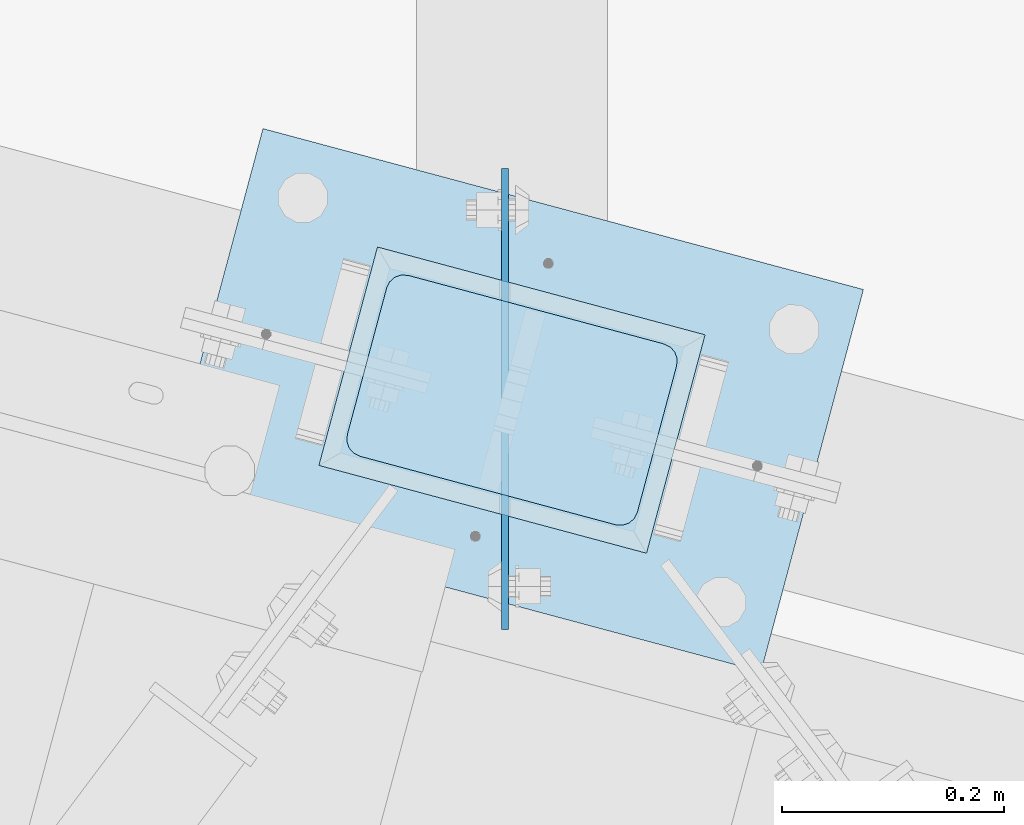
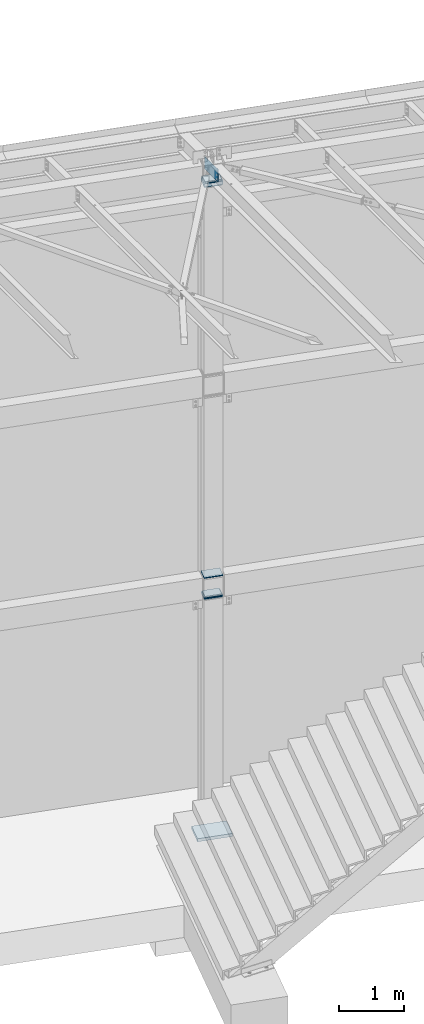
# One storey, part 1690 of 1763: 9 plates, 1 element without a shape of its own.
"""IFC2X3 building model written with IfcOpenShell, lengths in millimetres."""

from ifc_helpers import new_model, si_unit, frame, origin_with_axes, place, context, subcontext, project, spatial, faceted_brep, material, type_object, element, aggregate, save


model = new_model("IFC2X3")

# Units and contexts
model_context = context("Model", 3, precision=1e-05, world=origin_with_axes())
body_context = subcontext(model_context, "Body", "Model", "MODEL_VIEW")
ifc_project = project(units=[si_unit("LENGTHUNIT", "METRE", prefix="MILLI"), si_unit("AREAUNIT", "SQUARE_METRE"), si_unit("VOLUMEUNIT", "CUBIC_METRE"), si_unit("MASSUNIT", "GRAM", prefix="KILO"), si_unit("TIMEUNIT", "SECOND"), si_unit("PLANEANGLEUNIT", "RADIAN"), si_unit("SOLIDANGLEUNIT", "STERADIAN"), si_unit("THERMODYNAMICTEMPERATUREUNIT", "DEGREE_CELSIUS"), si_unit("LUMINOUSINTENSITYUNIT", "LUMEN")], contexts=[model_context])

# Site, building, storey
site_placement = place(None, origin_with_axes())
site = spatial("IfcSite", under=ifc_project, at=site_placement, CompositionType="ELEMENT")
building_placement = place(site_placement, origin_with_axes())
building = spatial("IfcBuilding", under=site, at=building_placement, Name="Undefined", CompositionType="ELEMENT")
storey_placement = place(building_placement, origin_with_axes())
storey = spatial("IfcBuildingStorey", under=building, at=storey_placement, Name="Undefined", CompositionType="ELEMENT", Elevation=0.0)

# Assembly, plates
assembly_placement = place(storey_placement, origin_with_axes())
assembly = element("IfcElementAssembly", 1, at=assembly_placement, inside=storey, Name="COLUMN", AssemblyPlace="NOTDEFINED", PredefinedType="RIGID_FRAME")
ifc_material_1 = material(Name="STEEL/A36")
plate_type_1 = type_object("IfcPlateType", PredefinedType="NOTDEFINED")
plate_1_placement = place(assembly_placement, frame((-31217.8672022489, 64503.1592394431, 4295.775), z_axis=(0.965913267114843, -0.258865912030785, 0.0), x_axis=(-0.258865912030778, -0.965913267114844, 3.00823476209188e-08)))
plate_1 = element("IfcPlate", 2, at=plate_1_placement, type_object=plate_type_1, material=ifc_material_1, Name="PLATE", context=body_context, shape_type="Brep", body=[
    faceted_brep([(-2.18278728425503e-11, -12.7000000000007, 15.875), (-1.67347025126219e-10, -12.7000000000007, 253.999999999985), (-1.67347025126219e-10, 12.7000000000007, 253.999999999985), (-2.18278728425503e-11, 12.7000000000007, 15.875), (1.20841242121242, -12.7000000000007, 260.075099488779), (1.20841242121242, 12.7000000000007, 260.075099488779), (4.649679848495, -12.7000000000007, 265.225320151323), (4.649679848495, 12.7000000000007, 265.225320151323), (9.79990051103232, -12.7000000000007, 268.666587578606), (9.79990051103232, 12.7000000000007, 268.666587578606), (15.8749999998181, -12.7000000000007, 269.874999999993), (15.8749999998181, 12.7000000000007, 269.874999999993), (152.400009155084, -12.7000000000007, 269.875000000073), (152.400009155084, 12.7000000000007, 269.875000000073), (158.475108643877, -12.7000000000007, 268.6665875787), (158.475108643877, 12.7000000000007, 268.6665875787), (163.625329306422, -12.7000000000007, 265.225320151425), (163.625329306422, 12.7000000000007, 265.225320151425), (167.066596733705, -12.7000000000007, 260.07509948888), (167.066596733705, 12.7000000000007, 260.07509948888), (168.275009155092, -12.7000000000007, 254.000000000087), (168.275009155092, 12.7000000000007, 254.000000000087), (168.275009155237, -12.7000000000007, 15.8750000001019), (168.275009155237, 12.7000000000007, 15.8750000001019), (167.066596733865, -12.7000000000007, 9.79990051130881), (167.066596733865, 12.7000000000007, 9.79990051130881), (163.625329306582, -12.7000000000007, 4.64967984876421), (163.625329306582, 12.7000000000007, 4.64967984876421), (158.475108644045, -12.7000000000007, 1.20841242148163), (158.475108644045, 12.7000000000007, 1.20841242148163), (152.400000000001, -12.6999998092651, 0.0), (152.400000000001, 12.6999998092651, 0.0), (15.8749999999854, -12.7000000000007, 0.0), (15.8749999999854, 12.7000000000007, 0.0), (9.79990051119239, -12.7000000000007, 1.20841242137976), (9.79990051119239, 12.7000000000007, 1.20841242137976), (4.64967984864779, -12.7000000000007, 4.64967984866234), (4.64967984864779, 12.7000000000007, 4.64967984866234), (1.20841242136521, -12.7000000000007, 9.79990051119967), (1.20841242136521, 12.7000000000007, 9.79990051119967)], [[[0, 1, 2, 3]], [[1, 4, 5, 2]], [[4, 6, 7, 5]], [[6, 8, 9, 7]], [[8, 10, 11, 9]], [[10, 12, 13, 11]], [[12, 14, 15, 13]], [[14, 16, 17, 15]], [[16, 18, 19, 17]], [[18, 20, 21, 19]], [[20, 22, 23, 21]], [[22, 24, 25, 23]], [[24, 26, 27, 25]], [[26, 28, 29, 27]], [[28, 30, 31, 29]], [[30, 32, 33, 31]], [[32, 34, 35, 33]], [[34, 36, 37, 35]], [[36, 38, 39, 37]], [[38, 0, 3, 39]], [[5, 7, 9, 11, 13, 15, 17, 19, 21, 23, 25, 27, 29, 31, 33, 35, 37, 39, 3, 2]], [[38, 36, 34, 32, 30, 28, 26, 24, 22, 20, 18, 16, 14, 12, 10, 8, 6, 4, 1, 0]]]),
])
plate_2_placement = place(assembly_placement, frame((-31217.8672022863, 64503.1592394531, 4254.5), z_axis=(0.965913267114843, -0.258865912030785, 0.0), x_axis=(-0.258865912030778, -0.965913267114844, 3.00823476209188e-08)))
plate_2 = element("IfcPlate", 3, at=plate_2_placement, type_object=plate_type_1, material=ifc_material_1, Name="PLATE", context=body_context, shape_type="Brep", body=[
    faceted_brep([(-2.18278728425503e-11, -12.7000000000007, 15.875), (-1.67347025126219e-10, -12.7000000000007, 253.999999999985), (-1.67347025126219e-10, 12.7000000000007, 253.999999999985), (-2.18278728425503e-11, 12.7000000000007, 15.875), (1.20841242121242, -12.7000000000007, 260.075099488779), (1.20841242121242, 12.7000000000007, 260.075099488779), (4.649679848495, -12.7000000000007, 265.225320151323), (4.649679848495, 12.7000000000007, 265.225320151323), (9.79990051103232, -12.7000000000007, 268.666587578606), (9.79990051103232, 12.7000000000007, 268.666587578606), (15.8749999998181, -12.7000000000007, 269.874999999993), (15.8749999998181, 12.7000000000007, 269.874999999993), (152.400009155084, -12.7000000000007, 269.875000000073), (152.400009155084, 12.7000000000007, 269.875000000073), (158.475108643877, -12.7000000000007, 268.6665875787), (158.475108643877, 12.7000000000007, 268.6665875787), (163.625329306422, -12.7000000000007, 265.225320151425), (163.625329306422, 12.7000000000007, 265.225320151425), (167.066596733705, -12.7000000000007, 260.07509948888), (167.066596733705, 12.7000000000007, 260.07509948888), (168.275009155092, -12.7000000000007, 254.000000000087), (168.275009155092, 12.7000000000007, 254.000000000087), (168.275009155237, -12.7000000000007, 15.8750000001019), (168.275009155237, 12.7000000000007, 15.8750000001019), (167.066596733865, -12.7000000000007, 9.79990051130881), (167.066596733865, 12.7000000000007, 9.79990051130881), (163.625329306582, -12.7000000000007, 4.64967984876421), (163.625329306582, 12.7000000000007, 4.64967984876421), (158.475108644045, -12.7000000000007, 1.20841242148163), (158.475108644045, 12.7000000000007, 1.20841242148163), (152.400000000001, -12.6999998092651, 0.0), (152.400000000001, 12.6999998092651, 0.0), (15.8749999999854, -12.7000000000007, 0.0), (15.8749999999854, 12.7000000000007, 0.0), (9.79990051119239, -12.7000000000007, 1.20841242137976), (9.79990051119239, 12.7000000000007, 1.20841242137976), (4.64967984864779, -12.7000000000007, 4.64967984866234), (4.64967984864779, 12.7000000000007, 4.64967984866234), (1.20841242136521, -12.7000000000007, 9.79990051119967), (1.20841242136521, 12.7000000000007, 9.79990051119967)], [[[0, 1, 2, 3]], [[1, 4, 5, 2]], [[4, 6, 7, 5]], [[6, 8, 9, 7]], [[8, 10, 11, 9]], [[10, 12, 13, 11]], [[12, 14, 15, 13]], [[14, 16, 17, 15]], [[16, 18, 19, 17]], [[18, 20, 21, 19]], [[20, 22, 23, 21]], [[22, 24, 25, 23]], [[24, 26, 27, 25]], [[26, 28, 29, 27]], [[28, 30, 31, 29]], [[30, 32, 33, 31]], [[32, 34, 35, 33]], [[34, 36, 37, 35]], [[36, 38, 39, 37]], [[38, 0, 3, 39]], [[5, 7, 9, 11, 13, 15, 17, 19, 21, 23, 25, 27, 29, 31, 33, 35, 37, 39, 3, 2]], [[38, 36, 34, 32, 30, 28, 26, 24, 22, 20, 18, 16, 14, 12, 10, 8, 6, 4, 1, 0]]]),
])
plate_3_placement = place(assembly_placement, frame((-31217.8672023171, 64503.1592394618, 12026.9), z_axis=(0.965913267114843, -0.258865912030785, 0.0), x_axis=(-0.258865912030778, -0.965913267114844, 3.00823476209188e-08)))
plate_3 = element("IfcPlate", 4, at=plate_3_placement, type_object=plate_type_1, material=ifc_material_1, Name="PLATE", context=body_context, shape_type="Brep", body=[
    faceted_brep([(-2.18278728425503e-11, -12.7000000000007, 15.875), (-1.67347025126219e-10, -12.7000000000007, 253.999999999985), (-1.67347025126219e-10, 12.7000000000007, 253.999999999985), (-2.18278728425503e-11, 12.7000000000007, 15.875), (1.20841242121242, -12.7000000000007, 260.075099488779), (1.20841242121242, 12.7000000000007, 260.075099488779), (4.649679848495, -12.7000000000007, 265.225320151323), (4.649679848495, 12.7000000000007, 265.225320151323), (9.79990051103232, -12.7000000000007, 268.666587578606), (9.79990051103232, 12.7000000000007, 268.666587578606), (15.8749999998181, -12.7000000000007, 269.874999999993), (15.8749999998181, 12.7000000000007, 269.874999999993), (152.400009155084, -12.7000000000007, 269.875000000073), (152.400009155084, 12.7000000000007, 269.875000000073), (158.475108643877, -12.7000000000007, 268.6665875787), (158.475108643877, 12.7000000000007, 268.6665875787), (163.625329306422, -12.7000000000007, 265.225320151425), (163.625329306422, 12.7000000000007, 265.225320151425), (167.066596733705, -12.7000000000007, 260.07509948888), (167.066596733705, 12.7000000000007, 260.07509948888), (168.275009155092, -12.7000000000007, 254.000000000087), (168.275009155092, 12.7000000000007, 254.000000000087), (168.275009155237, -12.7000000000007, 15.8750000001019), (168.275009155237, 12.7000000000007, 15.8750000001019), (167.066596733865, -12.7000000000007, 9.79990051130881), (167.066596733865, 12.7000000000007, 9.79990051130881), (163.625329306582, -12.7000000000007, 4.64967984876421), (163.625329306582, 12.7000000000007, 4.64967984876421), (158.475108644045, -12.7000000000007, 1.20841242148163), (158.475108644045, 12.7000000000007, 1.20841242148163), (152.400000000001, -12.6999998092651, 0.0), (152.400000000001, 12.6999998092651, 0.0), (15.8749999999854, -12.7000000000007, 0.0), (15.8749999999854, 12.7000000000007, 0.0), (9.79990051119239, -12.7000000000007, 1.20841242137976), (9.79990051119239, 12.7000000000007, 1.20841242137976), (4.64967984864779, -12.7000000000007, 4.64967984866234), (4.64967984864779, 12.7000000000007, 4.64967984866234), (1.20841242136521, -12.7000000000007, 9.79990051119967), (1.20841242136521, 12.7000000000007, 9.79990051119967)], [[[0, 1, 2, 3]], [[1, 4, 5, 2]], [[4, 6, 7, 5]], [[6, 8, 9, 7]], [[8, 10, 11, 9]], [[10, 12, 13, 11]], [[12, 14, 15, 13]], [[14, 16, 17, 15]], [[16, 18, 19, 17]], [[18, 20, 21, 19]], [[20, 22, 23, 21]], [[22, 24, 25, 23]], [[24, 26, 27, 25]], [[26, 28, 29, 27]], [[28, 30, 31, 29]], [[30, 32, 33, 31]], [[32, 34, 35, 33]], [[34, 36, 37, 35]], [[36, 38, 39, 37]], [[38, 0, 3, 39]], [[5, 7, 9, 11, 13, 15, 17, 19, 21, 23, 25, 27, 29, 31, 33, 35, 37, 39, 3, 2]], [[38, 36, 34, 32, 30, 28, 26, 24, 22, 20, 18, 16, 14, 12, 10, 8, 6, 4, 1, 0]]]),
])
plate_4_placement = place(assembly_placement, frame((-31217.8672023607, 64503.1592394731, 12115.8), z_axis=(0.965913267114843, -0.258865912030785, 0.0), x_axis=(-0.258865912030778, -0.965913267114844, 3.00823476209188e-08)))
plate_4 = element("IfcPlate", 5, at=plate_4_placement, type_object=plate_type_1, material=ifc_material_1, Name="PLATE", context=body_context, shape_type="Brep", body=[
    faceted_brep([(-2.18278728425503e-11, -12.7000000000007, 15.875), (-1.67347025126219e-10, -12.7000000000007, 253.999999999985), (-1.67347025126219e-10, 12.7000000000007, 253.999999999985), (-2.18278728425503e-11, 12.7000000000007, 15.875), (1.20841242121242, -12.7000000000007, 260.075099488779), (1.20841242121242, 12.7000000000007, 260.075099488779), (4.649679848495, -12.7000000000007, 265.225320151323), (4.649679848495, 12.7000000000007, 265.225320151323), (9.79990051103232, -12.7000000000007, 268.666587578606), (9.79990051103232, 12.7000000000007, 268.666587578606), (15.8749999998181, -12.7000000000007, 269.874999999993), (15.8749999998181, 12.7000000000007, 269.874999999993), (152.400009155084, -12.7000000000007, 269.875000000073), (152.400009155084, 12.7000000000007, 269.875000000073), (158.475108643877, -12.7000000000007, 268.6665875787), (158.475108643877, 12.7000000000007, 268.6665875787), (163.625329306422, -12.7000000000007, 265.225320151425), (163.625329306422, 12.7000000000007, 265.225320151425), (167.066596733705, -12.7000000000007, 260.07509948888), (167.066596733705, 12.7000000000007, 260.07509948888), (168.275009155092, -12.7000000000007, 254.000000000087), (168.275009155092, 12.7000000000007, 254.000000000087), (168.275009155237, -12.7000000000007, 15.8750000001019), (168.275009155237, 12.7000000000007, 15.8750000001019), (167.066596733865, -12.7000000000007, 9.79990051130881), (167.066596733865, 12.7000000000007, 9.79990051130881), (163.625329306582, -12.7000000000007, 4.64967984876421), (163.625329306582, 12.7000000000007, 4.64967984876421), (158.475108644045, -12.7000000000007, 1.20841242148163), (158.475108644045, 12.7000000000007, 1.20841242148163), (152.400000000001, -12.6999998092651, 0.0), (152.400000000001, 12.6999998092651, 0.0), (15.8749999999854, -12.7000000000007, 0.0), (15.8749999999854, 12.7000000000007, 0.0), (9.79990051119239, -12.7000000000007, 1.20841242137976), (9.79990051119239, 12.7000000000007, 1.20841242137976), (4.64967984864779, -12.7000000000007, 4.64967984866234), (4.64967984864779, 12.7000000000007, 4.64967984866234), (1.20841242136521, -12.7000000000007, 9.79990051119967), (1.20841242136521, 12.7000000000007, 9.79990051119967)], [[[0, 1, 2, 3]], [[1, 4, 5, 2]], [[4, 6, 7, 5]], [[6, 8, 9, 7]], [[8, 10, 11, 9]], [[10, 12, 13, 11]], [[12, 14, 15, 13]], [[14, 16, 17, 15]], [[16, 18, 19, 17]], [[18, 20, 21, 19]], [[20, 22, 23, 21]], [[22, 24, 25, 23]], [[24, 26, 27, 25]], [[26, 28, 29, 27]], [[28, 30, 31, 29]], [[30, 32, 33, 31]], [[32, 34, 35, 33]], [[34, 36, 37, 35]], [[36, 38, 39, 37]], [[38, 0, 3, 39]], [[5, 7, 9, 11, 13, 15, 17, 19, 21, 23, 25, 27, 29, 31, 33, 35, 37, 39, 3, 2]], [[38, 36, 34, 32, 30, 28, 26, 24, 22, 20, 18, 16, 14, 12, 10, 8, 6, 4, 1, 0]]]),
])
ifc_material_2 = material(Name="STEEL/A572-50")
plate_type_2 = type_object("IfcPlateType", PredefinedType="NOTDEFINED")
plate_5_placement = place(assembly_placement, frame((-31230.2044874384, 64524.5443925047, 4665.6625), z_axis=(0.965913267114843, -0.258865912030785, 0.0), x_axis=(-0.258865912030778, -0.965913267114844, 3.00823476209188e-08)))
plate_5 = element("IfcPlate", 6, at=plate_5_placement, type_object=plate_type_2, material=ifc_material_2, Name="PLATE", context=body_context, shape_type="Brep", body=[
    faceted_brep([(-7.27595761418343e-12, -7.9375, 0.0), (-1.96450855582952e-10, -7.9375, 304.799987792954), (-1.96450855582952e-10, 7.9375, 304.799987792954), (-7.27595761418343e-12, 7.9375, 0.0), (203.199996948031, -7.9375, 304.799987793078), (203.199996948031, 7.9375, 304.799987793078), (203.199996948228, -7.9375, 1.30967237055302e-10), (203.199996948228, 7.9375, 1.30967237055302e-10)], [[[0, 1, 2, 3]], [[1, 4, 5, 2]], [[4, 6, 7, 5]], [[6, 0, 3, 7]], [[5, 7, 3, 2]], [[6, 4, 1, 0]]]),
])
plate_6_placement = place(assembly_placement, frame((-31230.2044874766, 64524.544392515, 4275.1375), z_axis=(0.965913267114843, -0.258865912030785, 0.0), x_axis=(-0.258865912030778, -0.965913267114844, 3.00823476209188e-08)))
plate_6 = element("IfcPlate", 7, at=plate_6_placement, type_object=plate_type_2, material=ifc_material_2, Name="PLATE", context=body_context, shape_type="Brep", body=[
    faceted_brep([(-7.27595761418343e-12, -7.9375, 0.0), (-1.96450855582952e-10, -7.9375, 304.799987792954), (-1.96450855582952e-10, 7.9375, 304.799987792954), (-7.27595761418343e-12, 7.9375, 0.0), (203.199996948031, -7.9375, 304.799987793078), (203.199996948031, 7.9375, 304.799987793078), (203.199996948228, -7.9375, 1.30967237055302e-10), (203.199996948228, 7.9375, 1.30967237055302e-10)], [[[0, 1, 2, 3]], [[1, 4, 5, 2]], [[4, 6, 7, 5]], [[6, 0, 3, 7]], [[5, 7, 3, 2]], [[6, 4, 1, 0]]]),
])
plate_type_3 = type_object("IfcPlateType", PredefinedType="NOTDEFINED")
plate_7_placement = place(assembly_placement, frame((-31230.2140226508, 64524.5469474577, 12071.35), z_axis=(0.965913267114843, -0.258865912030785, 0.0), x_axis=(-0.258865912030778, -0.965913267114844, 3.00823476209188e-08)))
plate_7 = element("IfcPlate", 8, at=plate_7_placement, type_object=plate_type_3, material=ifc_material_2, Name="PLATE", context=body_context, shape_type="Brep", body=[
    faceted_brep([(-4.54747350886464e-13, -31.7499999999964, 0.0), (1.94268068298697e-09, -31.75, 304.799987793522), (1.94268068298697e-09, 31.75, 304.799987793522), (-5.91171556152403e-12, 31.7499999999891, 0.0), (203.199996948744, -31.75, 304.79998779326), (203.199996948744, 31.75, 304.79998779326), (203.199996946802, -31.75, -2.69210431724787e-10), (203.199996946802, 31.75, -2.69210431724787e-10)], [[[0, 1, 2, 3]], [[1, 4, 5, 2]], [[4, 6, 7, 5]], [[6, 0, 3, 7]], [[5, 7, 3, 2]], [[6, 4, 1, 0]]]),
])
plate_type_4 = type_object("IfcPlateType", PredefinedType="NOTDEFINED")
plate_8_placement = place(assembly_placement, frame((-31115.659617302, 64269.9244707515, 12404.725), z_axis=(0.0, 0.0, -1.0), x_axis=(0.0, 1.0, 0.0)))
plate_8 = element("IfcPlate", 9, at=plate_8_placement, type_object=plate_type_4, material=ifc_material_1, Name="PLATE", context=body_context, shape_type="Brep", body=[
    faceted_brep([(1.81898940354586e-12, -3.17500000000291, 0.0), (-89.3481750488281, -3.17499999999927, 0.0), (-89.3481750488281, 3.17499999999927, 0.0), (-1.81898940354586e-12, 3.17499999997381, 0.0), (-89.3481750488281, -3.17499999999927, 238.125), (-89.3481750488281, 3.17499999999927, 238.125), (325.119049072266, -3.17499999999927, 238.125), (325.119049072266, 3.17499999999927, 238.125), (325.119049072266, -3.17499999999927, 0.0), (325.119049072266, 3.17499999999927, 0.0)], [[[0, 1, 2, 3]], [[1, 4, 5, 2]], [[4, 6, 7, 5]], [[6, 8, 9, 7]], [[8, 0, 3, 9]], [[5, 7, 9, 3, 2]], [[8, 6, 4, 1, 0]]]),
])
ifc_material_3 = material(Name="STEEL/A572-GR.50")
plate_type_5 = type_object("IfcPlateType", PredefinedType="NOTDEFINED")
plate_9_placement = place(assembly_placement, frame((-31425.2121434054, 64287.5467514557, -200.025000000002), z_axis=(0.25886591203079, 0.965913267114842, 0.0), x_axis=(0.965913267114843, -0.258865912030785, 0.0)))
plate_9 = element("IfcPlate", 10, at=plate_9_placement, type_object=plate_type_5, material=ifc_material_3, Name="PLATE", context=body_context, shape_type="Brep", body=[
    faceted_brep([(0.0, -28.575, 0.0), (-2.18278728425503e-10, -28.575, 355.600006103494), (-2.18278728425503e-10, 28.575, 355.600006103494), (0.0, 28.575, 0.0), (558.799987792721, -28.575, 355.60000610385), (558.799987792721, 28.575, 355.60000610385), (558.79998779294, -28.575, 3.49245965480804e-10), (558.79998779294, 28.575, 3.49245965480804e-10)], [[[0, 1, 2, 3]], [[1, 4, 5, 2]], [[4, 6, 7, 5]], [[6, 0, 3, 7]], [[5, 7, 3, 2]], [[6, 4, 1, 0]]]),
])
aggregate(assembly, [plate_1, plate_2, plate_5, plate_6, plate_8, plate_3, plate_4, plate_7, plate_9])

save(model, "model.ifc")
